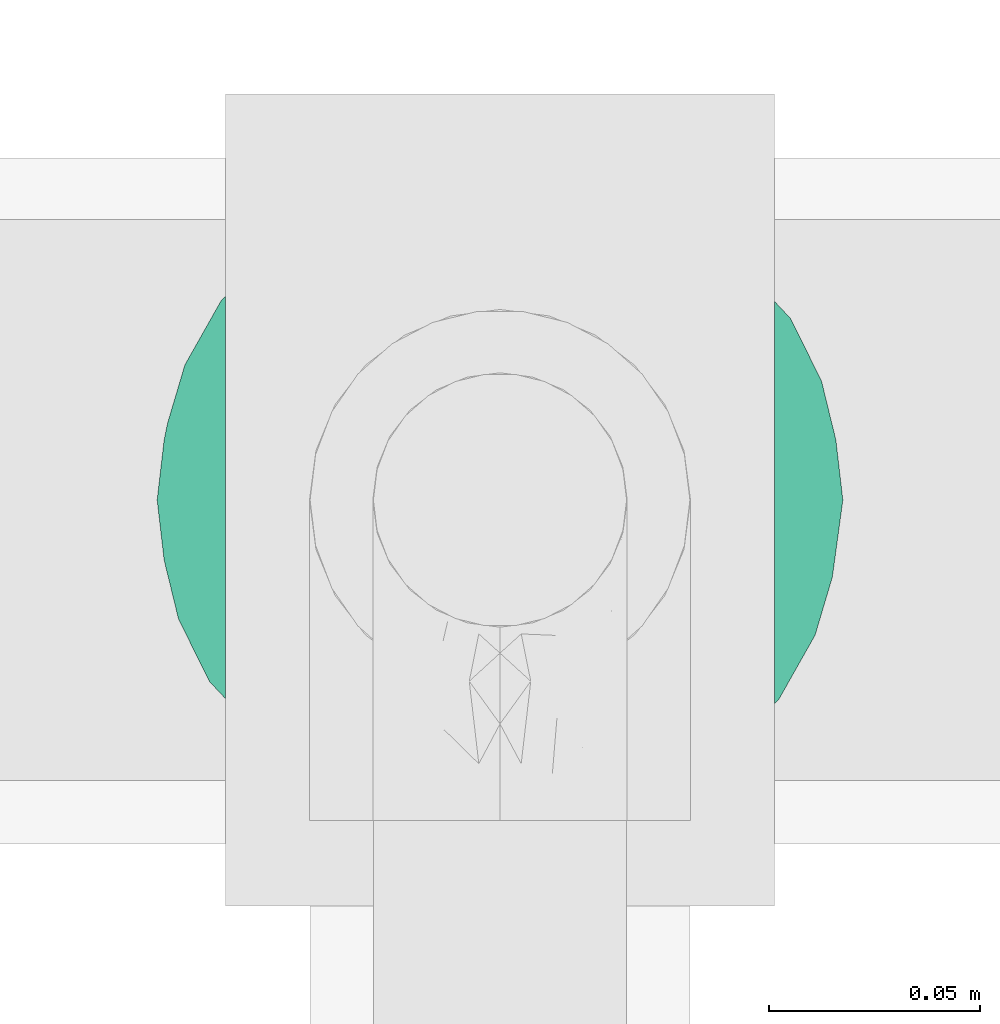
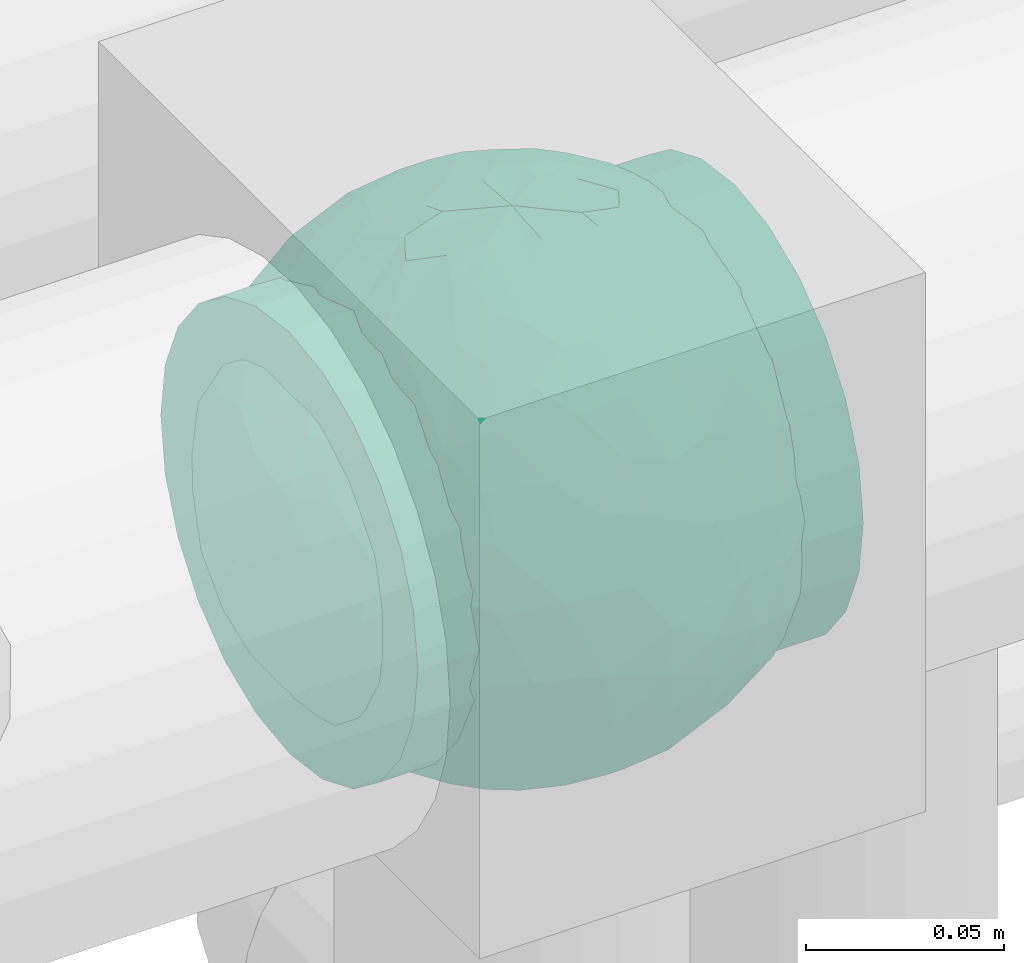
# One storey, part 715 of 827: 1 flow fitting.
"""IFC2X3 building model written with IfcOpenShell, lengths in millimetres."""

import ifcopenshell
import ifcopenshell.guid

model = None  # the IFC model being written
_history = None  # IfcOwnerHistory: only IFC2X3 demands one
_inside = {}  # id of a spatial element -> (the spatial element, [elements in it])
_under = {}  # id of a project, library or spatial element -> (it, [spatial elements below it])
_declared = {}  # id of a project -> (the project, [libraries it declares])
_typed = {}  # id of a type object -> (the type object, [elements of that type])
_made_of = {}  # id of a material, layer set ... -> (it, [elements and type objects made of it])


def new_model(schema):
    """Start an empty IFC model of exactly this schema.

    Asked for "IFC4X3", IfcOpenShell would pick the latest addendum, in which some entities
    have other attributes; the version numbers below select the first issue.
    IFC2X3 requires an IfcOwnerHistory on every rooted entity: one is made here for all.
    """
    global model, _history
    if schema == "IFC4X3":
        model = ifcopenshell.file(schema_version=(4, 3, 0, 0))
    else:
        model = ifcopenshell.file(schema=schema)
    _inside.clear()
    _under.clear()
    _declared.clear()
    _typed.clear()
    _made_of.clear()
    _history = None
    if model.schema == "IFC2X3":
        org = make("IfcOrganization", Name="unknown")
        user = make(
            "IfcPersonAndOrganization",
            ThePerson=make("IfcPerson", FamilyName="unknown"),
            TheOrganization=org,
        )
        app = make(
            "IfcApplication",
            ApplicationDeveloper=org,
            Version="unknown",
            ApplicationFullName="unknown",
            ApplicationIdentifier="unknown",
        )
        _history = make(
            "IfcOwnerHistory",
            OwningUser=user,
            OwningApplication=app,
            ChangeAction="ADDED",
            CreationDate=0,
        )
    return model


def make(cls, **values):
    """One entity of the class cls with the attributes given. An attribute that is None is left unset."""
    return model.create_entity(
        cls, **{name: value for name, value in values.items() if value is not None}
    )


def entity(cls, *values):
    """Any entity or typed value of the class cls, its attributes in the order of the schema. None: left unset."""
    e = model.create_entity(cls)
    for i, value in enumerate(values):
        if value is not None:
            e[i] = value
    return e


def rooted(cls, **values):
    """An entity with a GlobalId (a new one), such as an element, a storey or a relation."""
    return make(cls, GlobalId=ifcopenshell.guid.new(), OwnerHistory=_history, **values)


def si_unit(unit_type, name, prefix=None):
    """IfcSIUnit, for example si_unit("LENGTHUNIT", "METRE", prefix="MILLI")."""
    return make("IfcSIUnit", UnitType=unit_type, Prefix=prefix, Name=name)


def converted_unit(unit_type, name, factor, base, dimensions=None, offset=None):
    """IfcConversionBasedUnit, such as the inch: factor (a typed value) times the base unit."""
    return make(
        "IfcConversionBasedUnit"
        if offset is None
        else "IfcConversionBasedUnitWithOffset",
        ConversionOffset=offset,
        Dimensions=None
        if dimensions is None
        else entity("IfcDimensionalExponents", *dimensions),
        UnitType=unit_type,
        Name=name,
        ConversionFactor=make(
            "IfcMeasureWithUnit", ValueComponent=factor, UnitComponent=base
        ),
    )


def derived_unit(unit_type, elements):
    """IfcDerivedUnit: a product of units, each with its exponent."""
    return make(
        "IfcDerivedUnit",
        Elements=[
            make("IfcDerivedUnitElement", Unit=unit, Exponent=power)
            for unit, power in elements
        ],
        UnitType=unit_type,
    )


def assignment(units):
    """IfcUnitAssignment: the units of a project."""
    return None if units is None else make("IfcUnitAssignment", Units=units)


def point(xyz):
    """IfcCartesianPoint."""
    return None if xyz is None else make("IfcCartesianPoint", Coordinates=xyz)


def direction(xyz):
    """IfcDirection."""
    return None if xyz is None else make("IfcDirection", DirectionRatios=xyz)


def frame(location, z_axis=None, x_axis=None):
    """IfcAxis2Placement3D, a coordinate frame: its origin and axes. An axis left out is left unset."""
    return make(
        "IfcAxis2Placement3D",
        Location=point(location),
        Axis=direction(z_axis),
        RefDirection=direction(x_axis),
    )


def origin():
    """The frame at (0, 0, 0) with its axes left unset."""
    return frame((0.0, 0.0, 0.0))


def place(relative_to, where):
    """IfcLocalPlacement: puts the frame where relative to a parent placement (None: the world)."""
    return make(
        "IfcLocalPlacement", PlacementRelTo=relative_to, RelativePlacement=where
    )


def context(
    kind, dimensions, precision=None, world=None, true_north=None, identifier=None
):
    """IfcGeometricRepresentationContext, for example the 3D "Model" context."""
    return make(
        "IfcGeometricRepresentationContext",
        ContextIdentifier=identifier,
        ContextType=kind,
        CoordinateSpaceDimension=dimensions,
        Precision=precision,
        WorldCoordinateSystem=world,
        TrueNorth=true_north,
    )


def subcontext(parent, identifier, kind, view, scale=None):
    """IfcGeometricRepresentationSubContext, for example "Body" below "Model"."""
    return make(
        "IfcGeometricRepresentationSubContext",
        ContextIdentifier=identifier,
        ContextType=kind,
        ParentContext=parent,
        TargetScale=scale,
        TargetView=view,
    )


def project(units=None, contexts=None):
    """IfcProject with its units and contexts."""
    return rooted(
        "IfcProject",
        Name="project",
        RepresentationContexts=contexts,
        UnitsInContext=assignment(units),
    )


def spatial(cls, under=None, at=None, **own):
    """A site, building, storey or space (cls), placed at a placement, below another one or the project."""
    s = rooted(cls, ObjectPlacement=at, **own)
    if under is not None:
        _under.setdefault(under.id(), (under, []))[1].append(s)
    return s


def faces_of(points, faces, orient=None, outer=None):
    """IfcFace entities. A face is a list of loops; a loop is a list of indices into points, from 0.

    orient and outer hold one flag for each loop. By default every Orientation is true, the
    first loop of a face is its IfcFaceOuterBound and the others are IfcFaceBound.
    """
    made = []
    for i, loops in enumerate(faces):
        bounds = []
        for j, loop in enumerate(loops):
            is_outer = j == 0 if outer is None else outer[i][j]
            bounds.append(
                make(
                    "IfcFaceOuterBound" if is_outer else "IfcFaceBound",
                    Bound=make("IfcPolyLoop", Polygon=[points[k] for k in loop]),
                    Orientation=True if orient is None else orient[i][j],
                )
            )
        made.append(make("IfcFace", Bounds=bounds))
    return made


def faceted_brep(points, faces, orient=None, outer=None, voids=None):
    """IfcFacetedBrep: a solid bounded by flat faces; with voids (closed shells), ...WithVoids."""
    shared = [point(p) for p in points]
    hull = make("IfcClosedShell", CfsFaces=faces_of(shared, faces, orient, outer))
    if voids is None:
        return make("IfcFacetedBrep", Outer=hull)
    return make(
        "IfcFacetedBrepWithVoids",
        Outer=hull,
        Voids=[
            make(cls, CfsFaces=faces_of(shared, fs, o, b)) for cls, fs, o, b in voids
        ],
    )


def shape(context_of_items, identifier, shape_type, items):
    """IfcShapeRepresentation: the items that make up one representation, for example the "Body"."""
    return make(
        "IfcShapeRepresentation",
        ContextOfItems=context_of_items,
        RepresentationIdentifier=identifier,
        RepresentationType=shape_type,
        Items=items,
    )


def source(mapping_origin, context_of_items, identifier, shape_type, items):
    """IfcRepresentationMap: a shape defined once, which mapped items show again and again."""
    return make(
        "IfcRepresentationMap",
        MappingOrigin=mapping_origin,
        MappedRepresentation=shape(context_of_items, identifier, shape_type, items),
    )


def transform(
    local_origin,
    x_axis=None,
    y_axis=None,
    z_axis=None,
    scale=None,
    scale2=None,
    scale3=None,
    uniform=True,
):
    """IfcCartesianTransformationOperator3D, or its non-uniform kind. x_axis, y_axis, z_axis: its Axis1, 2, 3."""
    if uniform:
        return make(
            "IfcCartesianTransformationOperator3D",
            Axis1=direction(x_axis),
            Axis2=direction(y_axis),
            LocalOrigin=point(local_origin),
            Scale=scale,
            Axis3=direction(z_axis),
        )
    return make(
        "IfcCartesianTransformationOperator3DnonUniform",
        Axis1=direction(x_axis),
        Axis2=direction(y_axis),
        LocalOrigin=point(local_origin),
        Scale=scale,
        Axis3=direction(z_axis),
        Scale2=scale2,
        Scale3=scale3,
    )


def mapped(mapping_source, mapping_target):
    """IfcMappedItem: shows the shape of a source again, moved by a transform."""
    return make(
        "IfcMappedItem", MappingSource=mapping_source, MappingTarget=mapping_target
    )


def material(Name=None, Category=None):
    """IfcMaterial."""
    return make("IfcMaterial", Name=Name, Category=Category)


def material_list(materials):
    """IfcMaterialList."""
    return make("IfcMaterialList", Materials=materials)


def made_of(thing, what):
    """Note that an element or type object is made of a material, layer set ...; save() writes the relation."""
    if what is not None:
        _made_of.setdefault(what.id(), (what, []))[1].append(thing)
    return thing


def type_object(cls, material=None, **own):
    """A type object (cls), such as IfcWallType, which elements share."""
    return made_of(rooted(cls, **own), material)


def type_shapes(of_type, sources):
    """Give a type object the sources (RepresentationMaps) that its elements show as mapped items."""
    of_type.RepresentationMaps = sources


def element(
    cls,
    number,
    at=None,
    inside=None,
    cuts=None,
    type_object=None,
    material=None,
    context=None,
    identifier="Body",
    shape_type=None,
    held_by="IfcProductDefinitionShape",
    body=None,
    shapes=None,
    **own,
):
    """One element of the class cls, such as IfcWall. Its Tag is "e" and its number.

    at: its placement. inside: the storey or other place that contains it. cuts: it is an
    opening in that element (IfcRelVoidsElement). A single representation is given by context,
    identifier, shape_type and body (its items); several are given by shapes. held_by: the class
    of the entity that holds the representations. save() writes the other relations.
    """
    e = rooted(cls, Tag="e%d" % number, ObjectPlacement=at, **own)
    if body is not None:
        shapes = [shape(context, identifier, shape_type, body)]
    if shapes is not None:
        e.Representation = make(held_by, Representations=shapes)
    if inside is not None:
        _inside.setdefault(inside.id(), (inside, []))[1].append(e)
    if cuts is not None:
        rooted(
            "IfcRelVoidsElement", RelatingBuildingElement=cuts, RelatedOpeningElement=e
        )
    if type_object is not None:
        _typed.setdefault(type_object.id(), (type_object, []))[1].append(e)
    return made_of(e, material)


def aggregate(whole, parts):
    """IfcRelAggregates: a whole, such as a stair, and the parts it consists of."""
    return rooted("IfcRelAggregates", RelatingObject=whole, RelatedObjects=parts)


def save(model, path):
    """Write the relations noted so far, then the file.

    IfcRelAggregates (storeys below a building ...), IfcRelContainedInSpatialStructure (elements
    in a storey), IfcRelDefinesByType, IfcRelAssociatesMaterial and IfcRelDeclares: one each for
    every whole, place, type object, material and project.
    """
    for whole, parts in _under.values():
        aggregate(whole, parts)
    for where, things in _inside.values():
        rooted(
            "IfcRelContainedInSpatialStructure",
            RelatedElements=things,
            RelatingStructure=where,
        )
    for kind, things in _typed.values():
        rooted("IfcRelDefinesByType", RelatedObjects=things, RelatingType=kind)
    for what, things in _made_of.values():
        rooted("IfcRelAssociatesMaterial", RelatedObjects=things, RelatingMaterial=what)
    for by, libraries in _declared.values():
        rooted("IfcRelDeclares", RelatingContext=by, RelatedDefinitions=libraries)
    model.write(path)


model = new_model("IFC2X3")

# Units and contexts
model_context = context("Model", 3, precision=0.01, world=origin(), true_north=direction((6.12303176911189e-17, 1.0)))
body_context = subcontext(model_context, "Body", "Model", "MODEL_VIEW")
ifc_project = project(units=[si_unit("LENGTHUNIT", "METRE", prefix="MILLI"), si_unit("AREAUNIT", "SQUARE_METRE"), si_unit("VOLUMEUNIT", "CUBIC_METRE"), converted_unit("PLANEANGLEUNIT", "DEGREE", entity("IfcRatioMeasure", 0.0174532925199433), si_unit("PLANEANGLEUNIT", "RADIAN"), dimensions=[0, 0, 0, 0, 0, 0, 0]), si_unit("MASSUNIT", "GRAM", prefix="KILO"), derived_unit("MASSDENSITYUNIT", [(si_unit("MASSUNIT", "GRAM", prefix="KILO"), 1), (si_unit("LENGTHUNIT", "METRE"), -3)]), derived_unit("MOMENTOFINERTIAUNIT", [(si_unit("LENGTHUNIT", "METRE"), 4)]), si_unit("TIMEUNIT", "SECOND"), si_unit("FREQUENCYUNIT", "HERTZ"), si_unit("THERMODYNAMICTEMPERATUREUNIT", "DEGREE_CELSIUS"), derived_unit("THERMALTRANSMITTANCEUNIT", [(si_unit("MASSUNIT", "GRAM", prefix="KILO"), 1), (si_unit("THERMODYNAMICTEMPERATUREUNIT", "KELVIN"), -1), (si_unit("TIMEUNIT", "SECOND"), -3)]), derived_unit("VOLUMETRICFLOWRATEUNIT", [(si_unit("LENGTHUNIT", "METRE"), 3), (si_unit("TIMEUNIT", "SECOND"), -1)]), derived_unit("MASSFLOWRATEUNIT", [(si_unit("MASSUNIT", "GRAM", prefix="KILO"), 1), (si_unit("TIMEUNIT", "SECOND"), -1)]), derived_unit("ROTATIONALFREQUENCYUNIT", [(si_unit("TIMEUNIT", "SECOND"), -1)]), si_unit("ELECTRICCURRENTUNIT", "AMPERE"), si_unit("ELECTRICVOLTAGEUNIT", "VOLT"), si_unit("POWERUNIT", "WATT"), si_unit("FORCEUNIT", "NEWTON", prefix="KILO"), si_unit("ILLUMINANCEUNIT", "LUX"), si_unit("LUMINOUSFLUXUNIT", "LUMEN"), si_unit("LUMINOUSINTENSITYUNIT", "CANDELA"), derived_unit("USERDEFINED", [(si_unit("MASSUNIT", "GRAM", prefix="KILO"), -1), (si_unit("LENGTHUNIT", "METRE"), -2), (si_unit("TIMEUNIT", "SECOND"), 3), (si_unit("LUMINOUSFLUXUNIT", "LUMEN"), 1)]), derived_unit("LINEARVELOCITYUNIT", [(si_unit("LENGTHUNIT", "METRE"), 1), (si_unit("TIMEUNIT", "SECOND"), -1)]), si_unit("PRESSUREUNIT", "PASCAL"), derived_unit("USERDEFINED", [(si_unit("LENGTHUNIT", "METRE"), -2), (si_unit("MASSUNIT", "GRAM", prefix="KILO"), 1), (si_unit("TIMEUNIT", "SECOND"), -2)]), derived_unit("LINEARFORCEUNIT", [(si_unit("MASSUNIT", "GRAM", prefix="KILO"), 1), (si_unit("LENGTHUNIT", "METRE"), 1), (si_unit("TIMEUNIT", "SECOND"), -2), (si_unit("LENGTHUNIT", "METRE"), -1)]), derived_unit("PLANARFORCEUNIT", [(si_unit("MASSUNIT", "GRAM", prefix="KILO"), 1), (si_unit("LENGTHUNIT", "METRE"), 1), (si_unit("TIMEUNIT", "SECOND"), -2), (si_unit("LENGTHUNIT", "METRE"), -2)])], contexts=[model_context])

# Site, building, storey
site_placement = place(None, origin())
site = spatial("IfcSite", under=ifc_project, at=site_placement, CompositionType="ELEMENT")
building_placement = place(site_placement, origin())
building = spatial("IfcBuilding", under=site, at=building_placement, CompositionType="ELEMENT")
storey_placement = place(building_placement, frame((0.0, 0.0, 28200.0)))
storey = spatial("IfcBuildingStorey", under=building, at=storey_placement, Name="08", CompositionType="ELEMENT", Elevation=28200.0)

# Flow fitting
ifc_material_1 = material()
ifc_material_2 = material(Name="ADSK_")
ifc_material_list = material_list([ifc_material_1, ifc_material_2])
pipe_fitting_type = type_object("IfcPipeFittingType", Name="ADSK_1", PredefinedType="NOTDEFINED", material=ifc_material_list)
shared_shape = source(origin(), body_context, "Body", "Brep", [
    faceted_brep([(-65.0, 32.5, -56.29), (-65.0, 16.82, -62.79), (-65.0, 0.0, -65.0), (-65.0, -16.82, -62.79), (-65.0, -32.5, -56.29), (-65.0, -45.96, -45.96), (-65.0, -56.29, -32.5), (-65.0, -62.79, -16.82), (-65.0, -63.89, -8.41), (-65.0, -65.0, 0.0), (-65.0, -63.89, 8.41), (-65.0, -62.79, 16.82), (-65.0, -56.29, 32.5), (-65.0, -45.96, 45.96), (-65.0, -32.5, 56.29), (-65.0, -16.82, 62.79), (-65.0, 0.0, 65.0), (-65.0, 16.82, 62.79), (-65.0, 32.5, 56.29), (-65.0, 45.96, 45.96), (-65.0, 56.29, 32.5), (-65.0, 62.79, 16.82), (-65.0, 65.0, 0.0), (-65.0, 62.79, -16.82), (-65.0, 56.29, -32.5), (-65.0, 45.96, -45.96), (65.0, 0.0, -65.0), (65.0, 16.82, -62.79), (65.0, 32.5, -56.29), (65.0, 45.96, -45.96), (65.0, 56.29, -32.5), (65.0, 62.79, -16.82), (65.0, 65.0, 0.0), (65.0, 62.79, 16.82), (65.0, 56.29, 32.5), (65.0, 45.96, 45.96), (65.0, 32.5, 56.29), (65.0, 16.82, 62.79), (65.0, 0.0, 65.0), (65.0, -16.82, 62.79), (65.0, -32.5, 56.29), (65.0, -45.96, 45.96), (65.0, -56.29, 32.5), (65.0, -62.79, 16.82), (65.0, -63.89, 8.41), (65.0, -65.0, 0.0), (65.0, -63.89, -8.41), (65.0, -62.79, -16.82), (65.0, -56.29, -32.5), (65.0, -45.96, -45.96), (65.0, -32.5, -56.29), (65.0, -16.82, -62.79), (25.81, -64.3, 9.49), (27.5, -65.0, 0.0), (-27.5, -65.0, 0.0), (21.04, -62.54, 17.71), (4.82, -59.09, 27.07), (13.81, -60.49, 23.78), (9.32, -59.79, 25.43), (-25.81, -64.3, 9.48), (-26.66, -64.65, 4.74), (-21.05, -62.54, 17.7), (-13.81, -60.49, 23.78), (-9.32, -59.79, 25.43), (-4.83, -59.09, 27.07), (0.0, -59.09, 27.07), (26.66, -64.65, 4.74), (-25.81, -64.3, -9.48), (-26.66, -64.65, -4.74), (13.81, -60.49, -23.78), (9.32, -59.79, -25.43), (4.82, -59.09, -27.07), (25.81, -64.3, -9.49), (21.04, -62.54, -17.71), (26.66, -64.65, -4.74), (-4.83, -59.09, -27.07), (-9.32, -59.79, -25.43), (-13.81, -60.49, -23.78), (0.0, -59.09, -27.07), (-21.05, -62.54, -17.7), (0.0, -70.0, -27.5), (7.12, -70.0, -26.56), (13.75, -70.0, -23.82), (19.45, -70.0, -19.45), (23.82, -70.0, -13.75), (26.56, -70.0, -7.12), (27.5, -70.0, 0.0), (26.56, -70.0, 7.12), (23.82, -70.0, 13.75), (19.45, -70.0, 19.45), (13.75, -70.0, 23.82), (7.12, -70.0, 26.56), (0.0, -70.0, 27.5), (-7.12, -70.0, 26.56), (-13.75, -70.0, 23.82), (-19.45, -70.0, 19.45), (-23.82, -70.0, 13.75), (-26.56, -70.0, 7.12), (-27.5, -70.0, 0.0), (-26.56, -70.0, -7.12), (-23.82, -70.0, -13.75), (-19.45, -70.0, -19.45), (-13.75, -70.0, -23.82), (-7.12, -70.0, -26.56)], [[[0, 1, 2, 3, 4, 5, 6, 7, 8, 9, 10, 11, 12, 13, 14, 15, 16, 17, 18, 19, 20, 21, 22, 23, 24, 25]], [[26, 27, 28, 29, 30, 31, 32, 33, 34, 35, 36, 37, 38, 39, 40, 41, 42, 43, 44, 45, 46, 47, 48, 49, 50, 51]], [[44, 43, 52]], [[53, 45, 44]], [[9, 54, 10]], [[43, 55, 52]], [[56, 42, 12]], [[55, 43, 57]], [[42, 56, 58, 57]], [[42, 41, 13, 12]], [[57, 43, 42]], [[59, 11, 10]], [[10, 54, 60, 59]], [[59, 61, 11]], [[12, 62, 63, 64]], [[12, 11, 62]], [[12, 64, 65, 56]], [[62, 11, 61]], [[44, 52, 66, 53]], [[41, 40, 14, 13]], [[16, 15, 39, 38]], [[15, 14, 40, 39]], [[17, 16, 38, 37]], [[34, 33, 21, 20]], [[19, 18, 36, 35]], [[20, 19, 35, 34]], [[37, 36, 18, 17]], [[22, 21, 33, 32]], [[22, 32, 31, 23]], [[24, 30, 29, 25]], [[23, 31, 30, 24]], [[26, 51, 3, 2]], [[1, 0, 28, 27]], [[2, 1, 27, 26]], [[28, 0, 25, 29]], [[50, 4, 3, 51]], [[50, 49, 5, 4]], [[6, 5, 49, 48]], [[8, 67, 68, 54]], [[48, 69, 70, 71]], [[48, 47, 69]], [[6, 48, 71]], [[45, 53, 46]], [[8, 54, 9]], [[72, 73, 47]], [[46, 53, 74, 72]], [[47, 73, 69]], [[6, 75, 76, 77]], [[72, 47, 46]], [[77, 7, 6]], [[6, 71, 78, 75]], [[79, 67, 7]], [[67, 8, 7]], [[79, 7, 77]], [[80, 81, 82, 83, 84, 85, 86, 87, 88, 89, 90, 91, 92, 93, 94, 95, 96, 97, 98, 99, 100, 101, 102, 103]], [[97, 60, 98]], [[61, 96, 95]], [[97, 96, 59]], [[95, 94, 62]], [[97, 59, 60]], [[60, 54, 98]], [[59, 96, 61]], [[66, 52, 87]], [[93, 64, 63]], [[62, 61, 95]], [[92, 56, 65, 64]], [[90, 58, 91]], [[92, 64, 93]], [[56, 92, 91]], [[58, 90, 57]], [[55, 89, 88]], [[90, 89, 57]], [[52, 88, 87]], [[89, 55, 57]], [[56, 91, 58]], [[63, 62, 94]], [[86, 66, 87]], [[52, 55, 88]], [[66, 86, 53]], [[63, 94, 93]], [[85, 74, 86]], [[73, 84, 83]], [[85, 84, 72]], [[83, 82, 69]], [[85, 72, 74]], [[74, 53, 86]], [[72, 84, 73]], [[68, 67, 99]], [[81, 71, 70]], [[69, 73, 83]], [[80, 75, 78, 71]], [[102, 76, 103]], [[80, 71, 81]], [[75, 80, 103]], [[76, 102, 77]], [[79, 101, 100]], [[102, 101, 77]], [[67, 100, 99]], [[101, 79, 77]], [[75, 103, 76]], [[70, 69, 82]], [[98, 68, 99]], [[67, 79, 100]], [[68, 98, 54]], [[70, 82, 81]]]),
    faceted_brep([(-26.57, 76.36, -8.07), (-32.83, 71.49, -20.33), (-47.03, 64.85, -13.55), (22.24, -77.88, -6.48), (0.0, -81.25, 0.0), (14.57, -79.42, -9.02), (-19.55, 43.65, -65.68), (-6.7, 41.88, -69.3), (-15.5, 23.94, -76.08), (15.55, -78.16, 0.0), (20.63, -67.73, -39.86), (17.31, -55.39, -56.87), (33.39, -55.07, -49.54), (6.89, -77.99, -21.73), (13.76, -77.98, -18.22), (0.0, -79.9, -14.73), (-69.67, 30.72, -28.35), (-63.35, 45.14, -23.48), (-60.56, 38.81, -37.79), (-44.27, 66.26, 0.0), (8.9, -68.68, -42.49), (0.0, -57.53, -57.37), (-48.93, 45.14, -46.58), (-49.03, 57.11, -30.6), (-35.46, 62.54, -37.85), (76.18, -1.07, -28.23), (78.6, -12.72, -16.17), (71.53, -15.85, -35.12), (10.46, 67.82, -43.51), (0.0, 75.3, -30.53), (6.86, 78.01, -21.66), (-10.53, -67.73, -43.64), (0.0, -75.25, -30.63), (-6.89, -77.99, -21.73), (0.0, 81.25, 0.0), (15.55, 78.16, 0.0), (22.61, 77.77, -6.46), (-12.72, -56.34, -57.14), (-5.46, -45.53, -67.07), (44.37, 62.32, -27.38), (43.44, 67.56, -12.26), (56.18, 55.82, -18.18), (-13.79, 77.96, -18.26), (-25.89, 72.59, -25.72), (-16.58, 78.16, -14.76), (75.07, 31.09, 0.0), (74.86, 27.47, -15.59), (67.53, 42.93, -14.07), (13.79, 77.96, -18.26), (12.84, 79.64, -9.7), (21.38, 75.85, -19.79), (74.72, 15.85, -27.69), (79.59, 7.96, -14.27), (43.73, -67.56, -11.18), (57.45, -57.45, 0.0), (44.27, -66.26, 0.0), (63.35, -45.14, -23.48), (61.82, -51.54, -11.09), (49.12, -59.87, -24.59), (78.16, 15.55, 0.0), (50.83, -12.03, -62.24), (35.62, -9.55, -72.4), (43.7, 11.32, -67.56), (72.48, -29.04, -22.46), (-44.38, -62.32, -27.37), (-26.83, -74.87, -16.61), (-43.44, -67.56, -12.26), (-13.76, -77.98, -18.22), (-12.85, -79.64, -9.7), (-21.39, -75.84, -19.81), (-2.49, -31.04, -75.05), (8.59, -44.22, -67.62), (-74.72, -15.85, -27.69), (-68.67, -30.94, -30.47), (-74.55, -27.6, -16.8), (-75.07, 31.09, 0.0), (-71.41, 36.12, -14.04), (-75.88, 22.59, -18.27), (-22.61, -77.77, -6.46), (-16.87, -79.04, -8.34), (28.21, -26.53, -71.43), (13.03, -29.67, -74.51), (18.2, -9.78, -78.58), (-56.42, -55.66, -17.92), (6.0, 45.8, -66.84), (0.0, 57.69, -57.22), (-78.16, -15.55, 0.0), (-79.59, -7.96, -14.27), (32.83, -71.49, -20.33), (-15.55, -78.16, 0.0), (-20.62, 67.82, -39.72), (-33.11, 50.34, -54.51), (-61.82, 51.54, -11.09), (-66.26, 44.27, 0.0), (75.07, -31.09, 0.0), (66.26, -44.27, 0.0), (-6.86, 78.01, -21.66), (0.0, 79.92, -14.67), (26.82, 74.88, -16.61), (16.85, 79.04, -8.33), (-8.98, 69.99, -40.29), (38.78, -61.98, -35.46), (48.93, -45.14, -46.58), (55.26, -48.62, -34.41), (-71.53, 15.85, -35.12), (-78.76, 7.96, -18.29), (-17.06, 58.9, -53.31), (-15.55, 78.16, 0.0), (13.32, 55.85, -57.49), (21.86, 61.99, -47.75), (-15.13, 79.31, -9.05), (26.19, -72.28, -26.28), (17.27, -77.87, -15.49), (-29.57, -28.73, -70.02), (-26.25, -43.22, -63.6), (-42.18, -36.82, -58.88), (41.25, 41.74, -56.2), (54.79, 33.3, -49.91), (40.91, 28.53, -64.14), (38.98, -38.31, -60.12), (52.67, -28.88, -54.71), (68.84, 3.22, -43.04), (66.02, 21.29, -42.31), (-42.82, 33.53, -60.37), (-55.21, 10.46, -58.69), (-57.08, 27.98, -50.61), (-56.33, -15.85, -56.37), (-55.8, -33.3, -48.77), (-66.18, -20.5, -42.45), (31.09, 75.07, 0.0), (44.27, 66.26, 0.0), (57.45, 57.45, 0.0), (-31.09, -75.07, 0.0), (-57.45, -57.45, 0.0), (1.56, 67.82, -44.72), (-1.57, -67.73, -44.86), (22.55, 72.77, -28.25), (16.53, 72.17, -33.48), (-22.52, -72.77, -28.27), (-16.58, -72.47, -32.79), (28.96, -66.23, -37.11), (62.57, -34.08, -39.05), (62.37, -15.41, -49.74), (68.82, 31.09, -29.97), (-66.06, -1.38, -47.28), (-67.87, -42.27, -14.43), (29.1, 65.34, -38.54), (33.22, 68.08, -29.37), (46.02, 49.13, -45.5), (10.35, 15.34, -79.12), (0.0, 0.22, -81.25), (-29.12, -65.31, -38.57), (-22.07, -61.55, -48.23), (-33.19, -68.12, -29.33), (-46.02, -49.17, -45.45), (-34.11, 19.17, -71.21), (-23.02, 4.97, -77.76), (-40.38, 0.85, -70.5), (2.47, 31.35, -74.92), (16.3, 35.47, -71.26), (-13.73, -8.11, -79.67), (-28.12, -13.42, -75.04), (33.83, 54.01, -50.4), (26.1, 43.46, -63.49), (24.94, -42.3, -64.73), (-16.13, -35.64, -71.21), (0.28, -15.85, -79.69), (-13.57, -22.47, -76.89), (60.35, 45.14, -30.37), (-60.34, -45.14, -30.38), (-33.99, -54.1, -50.2), (-57.45, 57.45, 0.0), (-42.67, -18.04, -66.75), (-63.99, 15.14, -47.72), (-81.25, 0.0, 0.0), (-78.16, 15.55, 0.0), (-74.66, 0.0, -32.06), (-31.09, 75.07, 0.0), (31.09, -75.07, 0.0), (56.37, 15.85, -56.33), (28.0, 13.82, -75.01), (66.26, 44.27, 0.0), (81.25, 0.0, 0.0), (78.16, -15.55, 0.0), (-66.26, -44.27, 0.0), (-75.07, -31.09, 0.0), (-44.27, -66.26, 0.0), (26.57, 76.36, 8.07), (32.83, 71.49, 20.33), (47.03, 64.85, 13.55), (-22.24, -77.88, 6.48), (-14.57, -79.42, 9.02), (19.55, 43.65, 65.68), (6.7, 41.88, 69.3), (15.5, 23.94, 76.08), (-20.63, -67.73, 39.86), (-17.31, -55.39, 56.87), (-33.39, -55.07, 49.54), (-6.89, -77.99, 21.73), (-13.76, -77.98, 18.22), (0.0, -79.9, 14.73), (69.67, 30.72, 28.35), (63.35, 45.14, 23.48), (60.56, 38.81, 37.79), (-8.9, -68.68, 42.49), (0.0, -57.53, 57.37), (48.93, 45.14, 46.58), (49.03, 57.11, 30.6), (35.46, 62.54, 37.85), (-76.18, -1.07, 28.23), (-78.6, -12.72, 16.17), (-71.53, -15.85, 35.12), (-10.46, 67.82, 43.51), (0.0, 75.3, 30.53), (-6.86, 78.01, 21.66), (10.53, -67.73, 43.64), (0.0, -75.25, 30.63), (6.89, -77.99, 21.73), (-22.61, 77.77, 6.46), (12.72, -56.34, 57.14), (5.46, -45.53, 67.07), (-44.37, 62.32, 27.38), (-43.44, 67.56, 12.26), (-56.18, 55.82, 18.18), (13.79, 77.96, 18.26), (25.89, 72.59, 25.72), (16.58, 78.16, 14.76), (-74.86, 27.47, 15.59), (-67.53, 42.93, 14.07), (-13.79, 77.96, 18.26), (-12.84, 79.64, 9.7), (-21.38, 75.85, 19.79), (-74.72, 15.85, 27.69), (-79.59, 7.96, 14.27), (-43.73, -67.56, 11.18), (-63.35, -45.14, 23.48), (-61.82, -51.54, 11.09), (-49.12, -59.87, 24.59), (-50.83, -12.03, 62.24), (-35.62, -9.55, 72.4), (-43.7, 11.32, 67.56), (-72.48, -29.04, 22.46), (44.38, -62.32, 27.37), (26.83, -74.87, 16.61), (43.44, -67.56, 12.26), (13.76, -77.98, 18.22), (12.85, -79.64, 9.7), (21.39, -75.84, 19.81), (2.49, -31.04, 75.05), (-8.59, -44.22, 67.62), (74.72, -15.85, 27.69), (68.67, -30.94, 30.47), (74.55, -27.6, 16.8), (71.41, 36.12, 14.04), (75.88, 22.59, 18.27), (22.61, -77.77, 6.46), (16.87, -79.04, 8.34), (-28.21, -26.53, 71.43), (-13.03, -29.67, 74.51), (-18.2, -9.78, 78.58), (56.42, -55.66, 17.92), (-6.0, 45.8, 66.84), (0.0, 57.69, 57.22), (78.78, -14.01, 14.13), (-32.83, -71.49, 20.33), (20.62, 67.82, 39.72), (33.11, 50.34, 54.51), (61.82, 51.54, 11.09), (6.86, 78.01, 21.66), (0.0, 79.92, 14.67), (-26.82, 74.88, 16.61), (-16.85, 79.04, 8.33), (8.98, 69.99, 40.29), (-38.78, -61.98, 35.46), (-48.93, -45.14, 46.58), (-55.26, -48.62, 34.41), (71.53, 15.85, 35.12), (78.76, 7.96, 18.29), (17.06, 58.9, 53.31), (-13.32, 55.85, 57.49), (-21.86, 61.99, 47.75), (15.13, 79.31, 9.05), (-26.19, -72.28, 26.28), (-17.27, -77.87, 15.49), (29.57, -28.73, 70.02), (26.25, -43.22, 63.6), (42.18, -36.82, 58.88), (-41.25, 41.74, 56.2), (-54.79, 33.3, 49.91), (-40.91, 28.53, 64.14), (-38.98, -38.31, 60.12), (-52.67, -28.88, 54.71), (-68.84, 3.22, 43.04), (-66.02, 21.29, 42.31), (42.82, 33.53, 60.37), (55.21, 10.46, 58.69), (57.08, 27.98, 50.61), (56.33, -15.85, 56.37), (55.8, -33.3, 48.77), (66.18, -20.5, 42.45), (-1.56, 67.82, 44.72), (1.57, -67.73, 44.86), (-22.55, 72.77, 28.25), (-16.53, 72.17, 33.48), (22.52, -72.77, 28.27), (16.58, -72.47, 32.79), (-28.96, -66.23, 37.11), (-62.57, -34.08, 39.05), (-62.37, -15.41, 49.74), (-68.82, 31.09, 29.97), (66.06, -1.38, 47.28), (67.87, -42.27, 14.43), (-29.1, 65.34, 38.54), (-33.22, 68.08, 29.37), (-46.02, 49.13, 45.5), (-10.35, 15.34, 79.12), (0.0, 0.22, 81.25), (29.12, -65.31, 38.57), (22.07, -61.55, 48.23), (33.19, -68.12, 29.33), (46.02, -49.17, 45.45), (34.11, 19.17, 71.21), (23.02, 4.97, 77.76), (40.38, 0.85, 70.5), (-2.47, 31.35, 74.92), (-16.3, 35.47, 71.26), (13.73, -8.11, 79.67), (28.12, -13.42, 75.04), (-33.83, 54.01, 50.4), (-26.1, 43.46, 63.49), (-24.94, -42.3, 64.73), (16.13, -35.64, 71.21), (-0.28, -15.85, 79.69), (13.57, -22.47, 76.89), (-60.35, 45.14, 30.37), (60.34, -45.14, 30.38), (33.99, -54.1, 50.2), (42.67, -18.04, 66.75), (63.99, 15.14, 47.72), (74.66, 0.0, 32.06), (-56.37, 15.85, 56.33), (-28.0, 13.82, 75.01)], [[[0, 1, 2]], [[3, 4, 5]], [[6, 7, 8]], [[4, 3, 9]], [[10, 11, 12]], [[13, 14, 4]], [[13, 4, 15]], [[16, 17, 18]], [[19, 0, 2]], [[20, 21, 11]], [[22, 23, 24]], [[25, 26, 27]], [[28, 29, 30]], [[31, 32, 33]], [[34, 35, 36]], [[37, 38, 21]], [[39, 40, 41]], [[42, 43, 44]], [[45, 46, 47]], [[30, 34, 48]], [[49, 50, 48]], [[51, 46, 52]], [[53, 54, 55]], [[56, 57, 58]], [[46, 59, 52]], [[60, 61, 62]], [[27, 26, 63]], [[64, 65, 66]], [[67, 68, 69]], [[38, 70, 71]], [[72, 73, 74]], [[15, 33, 32]], [[75, 76, 77]], [[78, 65, 79]], [[80, 81, 82]], [[64, 66, 83]], [[84, 7, 85]], [[74, 86, 87]], [[88, 53, 3]], [[4, 89, 78]], [[24, 90, 91]], [[92, 76, 93]], [[94, 95, 63]], [[96, 34, 97]], [[36, 98, 99]], [[96, 42, 34]], [[96, 100, 90]], [[101, 102, 103]], [[77, 104, 105]], [[90, 106, 91]], [[34, 0, 107]], [[84, 85, 108]], [[109, 108, 28]], [[0, 110, 1]], [[14, 111, 112]], [[97, 30, 29]], [[39, 98, 40]], [[67, 33, 4]], [[113, 114, 115]], [[116, 117, 118]], [[119, 60, 120]], [[121, 122, 51]], [[123, 124, 125]], [[126, 127, 128]], [[129, 40, 36]], [[130, 131, 40]], [[132, 66, 78]], [[133, 83, 66]], [[97, 29, 96]], [[28, 108, 134]], [[100, 96, 29]], [[44, 34, 42]], [[15, 32, 13]], [[32, 31, 135]], [[20, 13, 32]], [[112, 4, 14]], [[48, 136, 137]], [[96, 90, 42]], [[90, 24, 43]], [[68, 67, 4]], [[67, 138, 139]], [[13, 10, 14]], [[140, 101, 111]], [[53, 58, 57]], [[141, 102, 120]], [[27, 142, 121]], [[46, 51, 143]], [[23, 2, 1]], [[125, 18, 22]], [[124, 126, 144]], [[73, 145, 74]], [[30, 137, 28]], [[28, 137, 109]], [[146, 147, 148]], [[149, 150, 8]], [[151, 152, 139]], [[152, 114, 37]], [[151, 153, 154]], [[155, 156, 157]], [[158, 84, 159]], [[156, 8, 150]], [[156, 160, 161]], [[155, 124, 123]], [[162, 116, 163]], [[119, 80, 60]], [[12, 102, 101]], [[81, 164, 71]], [[91, 123, 22]], [[100, 106, 90]], [[70, 38, 165]], [[81, 70, 166]], [[167, 113, 161]], [[156, 161, 157]], [[131, 47, 41]], [[36, 40, 98]], [[148, 39, 168]], [[146, 136, 147]], [[143, 117, 168]], [[146, 162, 109]], [[99, 34, 36]], [[133, 145, 83]], [[78, 66, 65]], [[154, 64, 169]], [[151, 138, 153]], [[115, 127, 126]], [[151, 170, 152]], [[79, 4, 78]], [[134, 100, 29]], [[85, 7, 106]], [[85, 106, 100]], [[91, 106, 6]], [[123, 6, 155]], [[91, 22, 24]], [[22, 18, 23]], [[43, 24, 1]], [[92, 17, 76]], [[1, 24, 23]], [[17, 2, 23]], [[92, 171, 2]], [[110, 0, 34]], [[6, 123, 91]], [[157, 161, 172]], [[144, 126, 128]], [[123, 125, 22]], [[124, 173, 125]], [[104, 16, 18]], [[18, 125, 173]], [[23, 18, 17]], [[105, 174, 175]], [[76, 17, 16]], [[105, 176, 87]], [[77, 175, 75]], [[176, 105, 104]], [[77, 76, 16]], [[76, 75, 93]], [[93, 171, 92]], [[177, 0, 19]], [[2, 17, 92]], [[104, 77, 16]], [[175, 77, 105]], [[3, 53, 178]], [[53, 88, 58]], [[88, 3, 5]], [[101, 58, 88]], [[56, 103, 141]], [[111, 101, 88]], [[101, 140, 12]], [[10, 20, 11]], [[119, 102, 12]], [[71, 70, 81]], [[119, 164, 80]], [[164, 12, 11]], [[80, 82, 61]], [[51, 25, 121]], [[119, 120, 102]], [[13, 20, 10]], [[20, 32, 135]], [[60, 142, 120]], [[56, 58, 103]], [[142, 141, 120]], [[63, 141, 27]], [[121, 60, 179]], [[141, 142, 27]], [[60, 121, 142]], [[122, 121, 179]], [[117, 122, 179]], [[143, 51, 122]], [[117, 179, 118]], [[168, 117, 148]], [[62, 118, 179]], [[159, 118, 180]], [[117, 143, 122]], [[143, 168, 47]], [[41, 47, 168]], [[47, 131, 181]], [[47, 46, 143]], [[46, 45, 59]], [[59, 182, 52]], [[26, 52, 182]], [[25, 51, 52]], [[26, 182, 183]], [[95, 57, 63]], [[26, 25, 52]], [[121, 25, 27]], [[94, 63, 26]], [[141, 63, 56]], [[53, 57, 54]], [[54, 57, 95]], [[63, 57, 56]], [[39, 41, 168]], [[41, 40, 131]], [[12, 164, 119]], [[164, 11, 71]], [[11, 21, 71]], [[38, 71, 21]], [[21, 135, 37]], [[38, 37, 165]], [[152, 37, 31]], [[165, 37, 114]], [[139, 31, 33]], [[151, 154, 170]], [[31, 139, 152]], [[67, 139, 33]], [[113, 165, 114]], [[167, 161, 160]], [[114, 170, 115]], [[172, 161, 113]], [[127, 115, 154]], [[172, 115, 126]], [[115, 172, 113]], [[157, 126, 124]], [[126, 157, 172]], [[124, 155, 157]], [[8, 156, 155]], [[160, 156, 150]], [[6, 8, 155]], [[8, 158, 149]], [[154, 169, 127]], [[128, 73, 72]], [[73, 127, 169]], [[176, 144, 128]], [[176, 128, 72]], [[173, 144, 104]], [[115, 170, 154]], [[114, 152, 170]], [[127, 73, 128]], [[73, 169, 145]], [[83, 145, 169]], [[145, 133, 184]], [[145, 185, 74]], [[74, 185, 86]], [[87, 86, 174]], [[105, 87, 174]], [[74, 87, 72]], [[64, 83, 169]], [[66, 132, 186]], [[167, 166, 70]], [[164, 81, 80]], [[149, 82, 150]], [[80, 61, 60]], [[82, 180, 61]], [[62, 180, 118]], [[112, 88, 5]], [[140, 14, 10]], [[166, 160, 150]], [[165, 167, 70]], [[150, 82, 166]], [[81, 166, 82]], [[167, 165, 113]], [[166, 167, 160]], [[88, 112, 111]], [[4, 112, 5]], [[144, 176, 104]], [[87, 176, 72]], [[101, 103, 58]], [[102, 141, 103]], [[60, 62, 179]], [[61, 180, 62]], [[14, 140, 111]], [[12, 140, 10]], [[48, 137, 30]], [[109, 137, 146]], [[162, 146, 148]], [[108, 85, 134]], [[109, 163, 108]], [[163, 159, 84]], [[116, 162, 148]], [[163, 109, 162]], [[163, 84, 108]], [[7, 84, 158]], [[118, 159, 163]], [[149, 159, 180]], [[8, 7, 158]], [[7, 6, 106]], [[117, 116, 148]], [[163, 116, 118]], [[98, 49, 99]], [[50, 49, 98]], [[34, 49, 48]], [[147, 98, 39]], [[136, 48, 50]], [[147, 39, 148]], [[137, 136, 146]], [[136, 50, 147]], [[98, 147, 50]], [[34, 99, 49]], [[65, 68, 79]], [[68, 65, 69]], [[153, 65, 64]], [[138, 67, 69]], [[153, 64, 154]], [[139, 138, 151]], [[138, 69, 153]], [[65, 153, 69]], [[4, 79, 68]], [[34, 30, 97]], [[4, 33, 15]], [[100, 134, 85]], [[29, 28, 134]], [[37, 135, 31]], [[20, 135, 21]], [[159, 149, 158]], [[82, 149, 180]], [[40, 129, 130]], [[186, 133, 66]], [[44, 1, 110]], [[90, 43, 42]], [[1, 44, 43]], [[34, 44, 110]], [[2, 171, 19]], [[0, 177, 107]], [[144, 173, 124]], [[18, 173, 104]], [[3, 178, 9]], [[55, 178, 53]], [[181, 45, 47]], [[94, 26, 183]], [[184, 185, 145]], [[35, 129, 36]], [[89, 132, 78]], [[187, 188, 189]], [[190, 4, 191]], [[192, 193, 194]], [[4, 190, 89]], [[195, 196, 197]], [[198, 199, 4]], [[198, 4, 200]], [[201, 202, 203]], [[130, 187, 189]], [[204, 205, 196]], [[206, 207, 208]], [[209, 210, 211]], [[212, 213, 214]], [[215, 216, 217]], [[34, 107, 218]], [[219, 220, 205]], [[221, 222, 223]], [[224, 225, 226]], [[75, 227, 228]], [[214, 34, 229]], [[230, 231, 229]], [[232, 227, 233]], [[234, 133, 186]], [[235, 236, 237]], [[227, 175, 233]], [[238, 239, 240]], [[211, 210, 241]], [[242, 243, 244]], [[245, 246, 247]], [[220, 248, 249]], [[250, 251, 252]], [[200, 217, 216]], [[45, 253, 254]], [[255, 243, 256]], [[257, 258, 259]], [[242, 244, 260]], [[261, 193, 262]], [[252, 183, 263]], [[264, 234, 190]], [[4, 9, 255]], [[208, 265, 266]], [[267, 253, 181]], [[185, 184, 241]], [[268, 34, 269]], [[218, 270, 271]], [[268, 224, 34]], [[268, 272, 265]], [[273, 274, 275]], [[254, 276, 277]], [[265, 278, 266]], [[34, 187, 35]], [[261, 262, 279]], [[280, 279, 212]], [[187, 281, 188]], [[199, 282, 283]], [[269, 214, 213]], [[221, 270, 222]], [[245, 217, 4]], [[284, 285, 286]], [[287, 288, 289]], [[290, 238, 291]], [[292, 293, 232]], [[294, 295, 296]], [[297, 298, 299]], [[177, 222, 218]], [[171, 223, 222]], [[178, 244, 255]], [[54, 260, 244]], [[269, 213, 268]], [[34, 230, 229]], [[212, 279, 300]], [[272, 268, 213]], [[226, 34, 224]], [[200, 216, 198]], [[216, 215, 301]], [[204, 198, 216]], [[229, 302, 303]], [[268, 265, 224]], [[265, 208, 225]], [[246, 245, 4]], [[245, 304, 305]], [[198, 195, 199]], [[306, 273, 282]], [[234, 237, 236]], [[307, 274, 291]], [[211, 308, 292]], [[227, 232, 309]], [[207, 189, 188]], [[296, 203, 206]], [[295, 297, 310]], [[251, 311, 252]], [[214, 303, 212]], [[212, 303, 280]], [[312, 313, 314]], [[315, 316, 194]], [[317, 318, 305]], [[318, 285, 219]], [[317, 319, 320]], [[321, 322, 323]], [[324, 261, 325]], [[322, 194, 316]], [[322, 326, 327]], [[321, 295, 294]], [[328, 287, 329]], [[290, 257, 238]], [[197, 274, 273]], [[258, 330, 249]], [[266, 294, 206]], [[272, 278, 265]], [[248, 220, 331]], [[258, 248, 332]], [[333, 284, 327]], [[322, 327, 323]], [[171, 228, 223]], [[218, 222, 270]], [[314, 221, 334]], [[312, 302, 313]], [[309, 288, 334]], [[312, 328, 280]], [[271, 34, 218]], [[54, 311, 260]], [[255, 244, 243]], [[320, 242, 335]], [[317, 304, 319]], [[286, 298, 297]], [[317, 336, 318]], [[256, 4, 255]], [[300, 272, 213]], [[262, 193, 278]], [[262, 278, 272]], [[266, 278, 192]], [[294, 192, 321]], [[266, 206, 208]], [[206, 203, 207]], [[225, 208, 188]], [[267, 202, 253]], [[188, 208, 207]], [[202, 189, 207]], [[267, 131, 189]], [[281, 187, 34]], [[192, 294, 266]], [[323, 327, 337]], [[310, 297, 299]], [[294, 296, 206]], [[295, 338, 296]], [[276, 201, 203]], [[203, 296, 338]], [[207, 203, 202]], [[277, 182, 59]], [[253, 202, 201]], [[263, 250, 252]], [[254, 59, 45]], [[339, 277, 276]], [[254, 253, 201]], [[253, 45, 181]], [[181, 131, 267]], [[129, 187, 130]], [[189, 202, 267]], [[276, 254, 201]], [[59, 254, 277]], [[190, 234, 132]], [[234, 264, 237]], [[272, 300, 262]], [[264, 190, 191]], [[273, 237, 264]], [[235, 275, 307]], [[282, 273, 264]], [[273, 306, 197]], [[195, 204, 196]], [[290, 274, 197]], [[249, 248, 258]], [[290, 330, 257]], [[330, 197, 196]], [[257, 259, 239]], [[232, 209, 292]], [[290, 291, 274]], [[198, 204, 195]], [[204, 216, 301]], [[238, 308, 291]], [[235, 237, 275]], [[308, 307, 291]], [[241, 307, 211]], [[292, 238, 340]], [[307, 308, 211]], [[238, 292, 308]], [[293, 292, 340]], [[288, 293, 340]], [[309, 232, 293]], [[288, 340, 289]], [[334, 288, 314]], [[240, 289, 340]], [[325, 289, 341]], [[288, 309, 293]], [[309, 334, 228]], [[223, 228, 334]], [[228, 171, 93]], [[228, 227, 309]], [[227, 75, 175]], [[175, 174, 233]], [[210, 233, 174]], [[209, 232, 233]], [[210, 174, 86]], [[184, 236, 241]], [[210, 209, 233]], [[292, 209, 211]], [[185, 241, 210]], [[307, 241, 235]], [[234, 236, 133]], [[133, 236, 184]], [[241, 236, 235]], [[221, 223, 334]], [[222, 177, 19]], [[197, 330, 290]], [[330, 196, 249]], [[196, 205, 249]], [[220, 249, 205]], [[205, 301, 219]], [[220, 219, 331]], [[318, 219, 215]], [[331, 219, 285]], [[305, 215, 217]], [[317, 320, 336]], [[215, 305, 318]], [[245, 305, 217]], [[284, 331, 285]], [[333, 327, 326]], [[285, 336, 286]], [[337, 327, 284]], [[298, 286, 320]], [[337, 286, 297]], [[286, 337, 284]], [[323, 297, 295]], [[297, 323, 337]], [[295, 321, 323]], [[194, 322, 321]], [[326, 322, 316]], [[192, 194, 321]], [[194, 324, 315]], [[320, 335, 298]], [[299, 251, 250]], [[251, 298, 335]], [[339, 310, 299]], [[339, 299, 250]], [[338, 310, 276]], [[286, 336, 320]], [[285, 318, 336]], [[298, 251, 299]], [[251, 335, 311]], [[260, 311, 335]], [[311, 54, 95]], [[311, 94, 252]], [[252, 94, 183]], [[182, 277, 263]], [[182, 263, 183]], [[339, 263, 277]], [[242, 260, 335]], [[244, 178, 55]], [[333, 332, 248]], [[330, 258, 257]], [[315, 259, 316]], [[257, 239, 238]], [[259, 341, 239]], [[240, 341, 289]], [[283, 264, 191]], [[306, 199, 195]], [[332, 326, 316]], [[331, 333, 248]], [[316, 259, 332]], [[258, 332, 259]], [[333, 331, 284]], [[332, 333, 326]], [[264, 283, 282]], [[4, 283, 191]], [[310, 339, 276]], [[263, 339, 250]], [[273, 275, 237]], [[274, 307, 275]], [[238, 240, 340]], [[239, 341, 240]], [[199, 306, 282]], [[197, 306, 195]], [[229, 303, 214]], [[280, 303, 312]], [[328, 312, 314]], [[279, 262, 300]], [[280, 329, 279]], [[329, 325, 261]], [[287, 328, 314]], [[329, 280, 328]], [[329, 261, 279]], [[193, 261, 324]], [[289, 325, 329]], [[315, 325, 341]], [[194, 193, 324]], [[193, 192, 278]], [[288, 287, 314]], [[329, 287, 289]], [[270, 230, 271]], [[231, 230, 270]], [[313, 270, 221]], [[302, 229, 231]], [[313, 221, 314]], [[303, 302, 312]], [[302, 231, 313]], [[270, 313, 231]], [[34, 271, 230]], [[243, 246, 256]], [[246, 243, 247]], [[319, 243, 242]], [[304, 245, 247]], [[319, 242, 320]], [[305, 304, 317]], [[304, 247, 319]], [[243, 319, 247]], [[4, 256, 246]], [[34, 214, 269]], [[4, 217, 200]], [[4, 199, 283]], [[213, 212, 300]], [[219, 301, 215]], [[204, 301, 205]], [[325, 315, 324]], [[259, 315, 341]], [[19, 171, 222]], [[55, 54, 244]], [[226, 188, 281]], [[265, 225, 224]], [[188, 226, 225]], [[34, 226, 281]], [[189, 131, 130]], [[187, 129, 35]], [[310, 338, 295]], [[203, 338, 276]], [[190, 132, 89]], [[186, 132, 234]], [[93, 75, 228]], [[185, 210, 86]], [[95, 94, 311]], [[107, 177, 218]], [[9, 178, 255]]]),
])
type_shapes(pipe_fitting_type, [shared_shape])
flow_fitting_placement = place(storey_placement, frame((59596.67, 17930.1, 2900.0), z_axis=(0.0, -1.0, 0.0), x_axis=(1.0, 0.0, 0.0)))
element("IfcFlowFitting", 1, at=flow_fitting_placement, inside=storey, type_object=pipe_fitting_type, material=ifc_material_list, Name="ADSK_1", ObjectType="ADSK_1", context=body_context, shape_type="MappedRepresentation", body=[
    mapped(shared_shape, transform((0.0, 0.0, 0.0), scale=1.0)),
])

save(model, "model.ifc")
